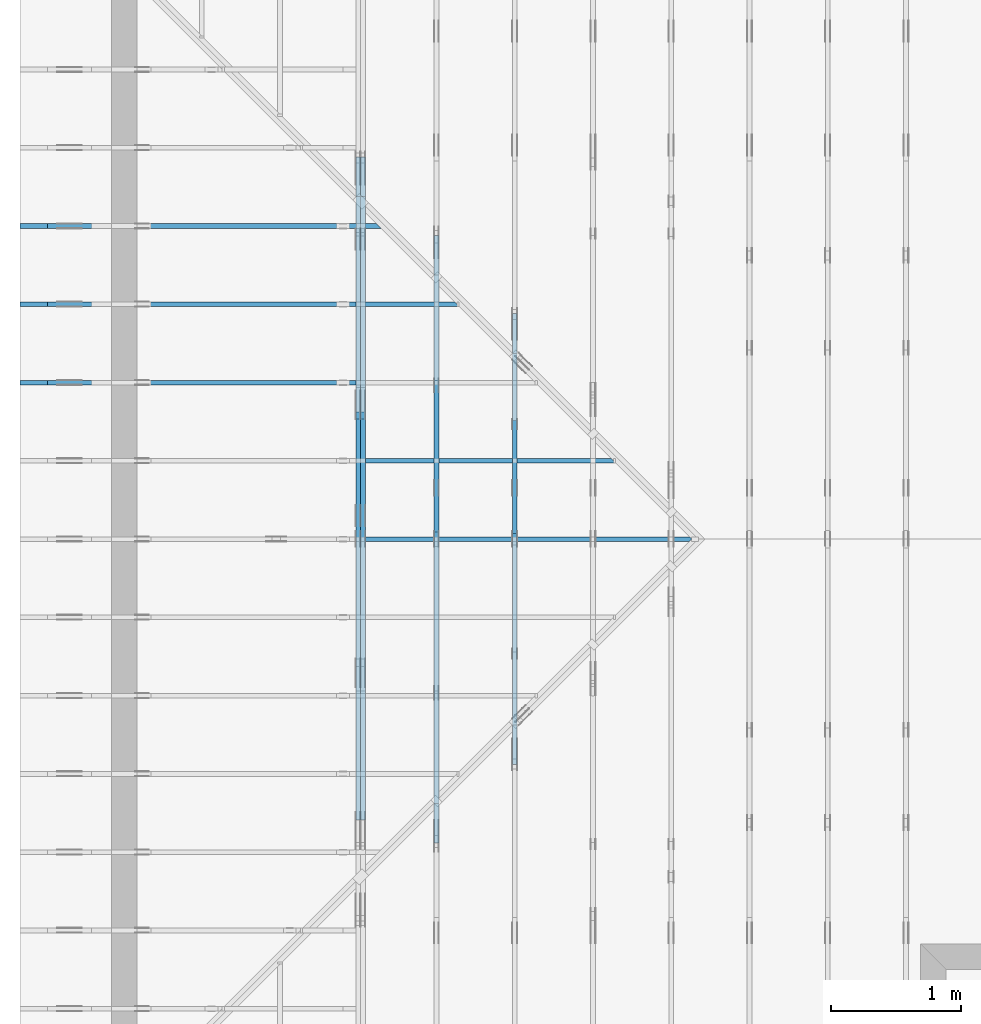
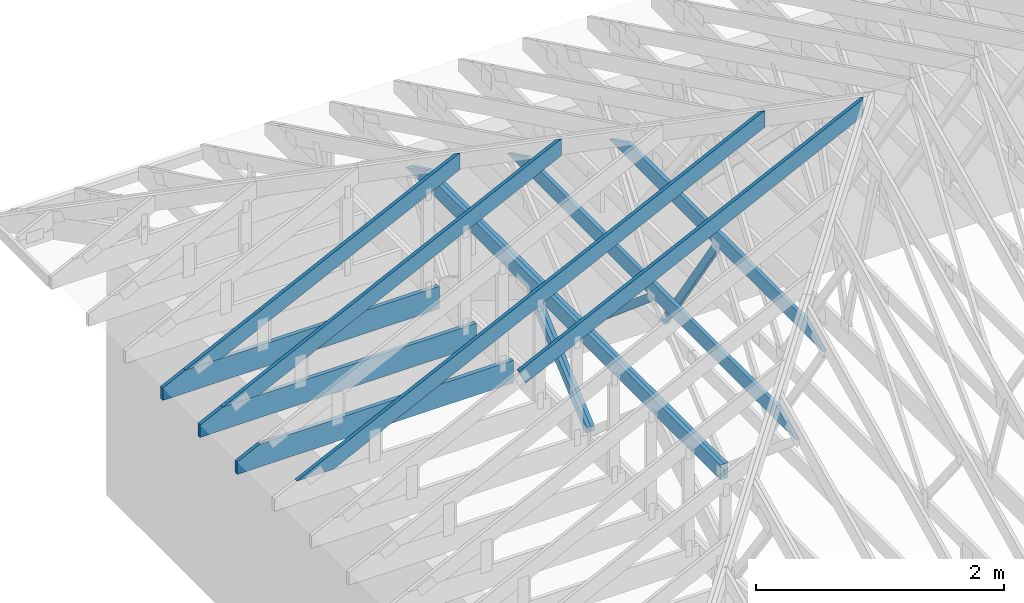
# One storey, part 7 of 159: 15 members, 8 elements without a shape of their own.
"""IFC2X3 building model written with IfcOpenShell, lengths in millimetres."""

from ifc_helpers import new_model, si_unit, frame, origin, origin_with_axes, origin_2d, place, context, project, spatial, faceted_brep, element, aggregate, save


model = new_model("IFC2X3")

# Units and contexts
model_context = context("Model", 3, precision=1e-05, world=origin())
plan_context = context("Plan", 2, precision=1e-05, world=origin_2d())
ifc_project = project(units=[si_unit("LENGTHUNIT", "METRE", prefix="MILLI"), si_unit("AREAUNIT", "SQUARE_METRE"), si_unit("VOLUMEUNIT", "CUBIC_METRE"), si_unit("SOLIDANGLEUNIT", "STERADIAN"), si_unit("PLANEANGLEUNIT", "RADIAN"), si_unit("MASSUNIT", "GRAM"), si_unit("TIMEUNIT", "SECOND"), si_unit("THERMODYNAMICTEMPERATUREUNIT", "DEGREE_CELSIUS"), si_unit("LUMINOUSINTENSITYUNIT", "LUMEN")], contexts=[model_context, plan_context])

# Site, building, storey
site_placement = place(None, origin_with_axes())
site = spatial("IfcSite", under=ifc_project, at=site_placement, CompositionType="ELEMENT")
building_placement = place(site_placement, origin_with_axes())
building = spatial("IfcBuilding", under=site, at=building_placement, Name="Plan 1", CompositionType="ELEMENT")
storey_placement = place(building_placement, origin_with_axes())
storey = spatial("IfcBuildingStorey", under=building, at=storey_placement, Name="Etasje 1", CompositionType="ELEMENT", Elevation=0.0)

# Assembly, member
assembly_1_placement = place(storey_placement, frame((-700.000000000007, 4482.000534935255, 1.1021457184401395e-15), z_axis=(0.0, -1.0, 6.123031769111886e-17), x_axis=(1.0, 0.0, 0.0)))
assembly_1 = element("IfcElementAssembly", 1, at=assembly_1_placement, inside=storey, Name="S1 (23)", AssemblyPlace="FACTORY", PredefinedType="TRUSS")
member_1_placement = place(assembly_1_placement, frame((1996.283952199432, 928.9876521486785, -36.000004249148034), z_axis=(0.0, 0.0, 1.0), x_axis=(0.8987940462991673, 0.43837114678907735, 0.0)))
member_1 = element("IfcMember", 2, at=member_1_placement, Name="S1-O29", context=model_context, shape_type="Brep", body=[
    faceted_brep([(3580.0000763961416, 148.000000161535, 18.000004249150606), (3507.8156524450424, 5.344837177290174e-06, 18.000001218995067), (3487.788816001169, 5.018745241613942e-06, 6.821210263296962e-13), (3559.9732414248656, 148.00000032212813, 4.140368901062175e-06), (3507.81565284729, 1.6058622144292368e-07, 18.000004249148027), (3487.788818359375, 1.6058622622381771e-07, 36.00000424914803), (4.049084132590763e-31, 1.6058686689906988e-07, 36.00000424914803), (1.8367099231598242e-38, 1.6058686469477845e-07, 4.249148027213323e-06), (3487.788818359375, 1.6058622401952628e-07, 4.249148027213323e-06), (3580.0000787542895, 147.9999953034071, 17.999999999927468), (3559.9732423104315, 147.99999497730846, 36.00000121893754), (3487.788818359381, 1.6058686469477834e-07, 36.00000424914788), (3507.8156533306415, 2.2737367544323206e-13, 18.000004140350484), (7.639614159415942e-05, 148.00000016153444, 4.249150464374907e-06), (7.639614159415942e-05, 148.00000016153444, 36.000004249150464), (3559.9732419082256, 148.00000016153422, 36.000004249150464), (3580.0000763961416, 148.00000016153422, 18.000004249150464), (3559.9732419082256, 148.00000016153422, 4.249150464374907e-06), (7.639614204890677e-05, 5.371931592890178e-07, 4.175160519537258e-06), (7.639614205111106e-05, 5.371931592890178e-07, 36.00000424914803), (7.639614206923523e-05, 148.00000331244257, 36.00000485022119), (7.639614206703094e-05, 148.00000331244257, 2.296806940194074e-06), (3559.9732437133853, 148.0000001605872, 36.00000424914803), (5.9117155615240335e-12, 148.0000001605872, 36.00000424914803), (5.9117155615240335e-12, 1.6152262105606496e-07, 36.00000424914803), (3487.7888183593814, 1.6152262105606496e-07, 36.00000424914803), (9.693633455754025e-05, 148.0000001615225, 4.249148027213335e-06), (3559.9732414675846, 148.0000001615225, 4.249148463169908e-06), (3487.7888161135816, 1.6153398973983712e-07, 4.249148454330158e-06), (9.69363350122876e-05, 1.6153398973983712e-07, 4.249148027213335e-06)], [[[0, 1, 2, 3]], [[4, 5, 6, 7, 8]], [[9, 10, 11, 12]], [[13, 14, 15, 16, 17]], [[18, 19, 20, 21]], [[22, 23, 24, 25]], [[26, 27, 28, 29]]]),
])
aggregate(assembly_1, [member_1])

assembly_2_placement = place(storey_placement, frame((-700.000000000007, 5081.993668449246, 1.1021457184401395e-15), z_axis=(0.0, -1.0, 6.123031769111886e-17), x_axis=(1.0, 0.0, 0.0)))
assembly_2 = element("IfcElementAssembly", 3, at=assembly_2_placement, inside=storey, Name="S2 (15)", AssemblyPlace="FACTORY", PredefinedType="TRUSS")
member_2_placement = place(assembly_2_placement, frame((276.06008258286255, 89.9784114862661, -36.000000217582134), z_axis=(0.0, 0.0, 1.0), x_axis=(0.8987940462991673, 0.43837114678907735, 0.0)))
member_2 = element("IfcMember", 4, at=member_2_placement, Name="S2-O8", context=model_context, shape_type="Brep", body=[
    faceted_brep([(4846.397802857349, 147.99999481741372, 36.00000324779239), (4774.21337890625, 7.155449566198513e-10, 36.0000002175816), (4734.159708963717, 3.219075779270497e-07, -4.547473508864641e-13), (4806.3441329148145, 147.99999513860587, 3.0302103368740063e-06), (0.0003410761450481914, 147.99999999999386, 2.175821265382183e-07), (0.0003410761450481914, 147.9999999999941, 36.00000021758213), (4846.397802013646, 147.99999999999378, 36.00000021758213), (4806.3441330378155, 147.99999999999358, 2.175821265382183e-07), (0.0003821565404109606, 148.00000000071233, 2.175821265382651e-07), (4806.344132156541, 148.00000000071233, 2.1758271512617458e-07), (4734.159706802537, 0.0, 2.17582706286424e-07), (303.44520637529064, 0.0, 2.1758216369831107e-07), (303.445127460673, 1.3804992704535834e-09, 2.175821265382183e-07), (303.445127460673, 1.3804992704535834e-09, 36.00000021758213), (0.0001557475417470755, 148.00000154232075, 36.00000021758213), (0.0001557475417470755, 148.00000154232075, 2.175821265382183e-07), (4774.213378024973, 7.207033695502529e-10, 36.00000021758213), (303.44535358039394, 7.21524609189633e-10, 36.00000021758213), (303.44535358039394, 7.215224048981962e-10, 2.175821265382183e-07), (4734.159709049144, 7.207085227554443e-10, 2.175821265382183e-07), (4846.397804260253, 148.00000000071532, 36.00000021758213), (0.0, 148.00000000071532, 36.00000021758213), (303.44531249999994, 1.3808119092573179e-09, 36.00000021758213), (4774.21337890625, 1.3808119092573179e-09, 36.00000021758213)], [[[0, 1, 2, 3]], [[4, 5, 6, 7]], [[8, 9, 10, 11]], [[12, 13, 14, 15]], [[16, 17, 18, 19]], [[20, 21, 22, 23]]]),
])
aggregate(assembly_2, [member_2])

assembly_3_placement = place(storey_placement, frame((-700.000000000007, 5681.993668449246, 1.1021457184401395e-15), z_axis=(0.0, -1.0, 6.123031769111886e-17), x_axis=(1.0, 0.0, 0.0)))
assembly_3 = element("IfcElementAssembly", 5, at=assembly_3_placement, inside=storey, Name="S3 (13)", AssemblyPlace="FACTORY", PredefinedType="TRUSS")
member_3_placement = place(assembly_3_placement, frame((2575.022261404757, 223.00000000093104, -36.0), z_axis=(0.0, 0.0, 1.0), x_axis=(-1.0, 1.2246063538223773e-16, 0.0)))
member_3 = element("IfcMember", 6, at=member_3_placement, Name="S3-U11", context=model_context, shape_type="Brep", body=[
    faceted_brep([(2575.022261404768, 223.00000000093135, 36.0), (4.460788204596611e-05, 223.00000000093135, 36.0), (4.460788204596611e-05, 9.310383575211745e-10, 36.0), (2363.8409717319055, 9.310383575211745e-10, 36.0), (2575.022261404761, 103.00000000093135, 36.0), (4.460788204596611e-05, 223.00000000093135, 5.462709578404924e-21), (2575.022261404768, 223.00000000093135, 3.1533886225503453e-13), (2575.022261404761, 103.00000000093135, 3.1533886225503367e-13), (2363.8409717319055, 9.310383575211745e-10, 2.894774673408554e-13), (4.460788204596611e-05, 9.310383575211745e-10, 5.462709578404924e-21), (1.1401554882727804e-25, 9.310383575211745e-10, -6.981208276421509e-42), (2.2042914369942947e-15, 9.310383575211745e-10, 36.0), (2.9513013127233304e-14, 223.00000000093104, 36.0), (2.730872169035303e-14, 223.00000000093104, -1.6721217048386645e-30), (2363.8409657211496, 5.20089044280899e-13, -3.184521740898993e-29), (2363.8409657211496, 5.222933357177793e-13, 36.0), (8.67712118026388e-28, 9.310405618126114e-10, 36.0), (0.0, 9.310383575211745e-10, 0.0), (2575.022261404761, 103.00000000064097, -3.7865323450608567e-29), (2575.022261404761, 103.00000000064097, 36.0), (2363.8409657211496, 5.684341886080801e-13, 36.0), (2363.8409657211496, 5.684341886080801e-13, -2.524354896707238e-29), (2575.022261404755, 223.00000000093135, -7.825500179792437e-28), (2575.022261404755, 223.00000000093135, 36.0), (2575.022261404755, 103.00000000064031, 36.0), (2575.022261404755, 103.00000000064031, -3.534096855390133e-28), (0.0, 223.00000000093104, 0.0), (0.0, 223.00000000093104, 36.0), (2575.022261404768, 223.00000000093144, 36.0), (2575.022261404768, 223.00000000093146, 6.310887241768095e-30)], [[[0, 1, 2, 3, 4]], [[5, 6, 7, 8, 9]], [[10, 11, 12, 13]], [[14, 15, 16, 17]], [[18, 19, 20, 21]], [[22, 23, 24, 25]], [[26, 27, 28, 29]]]),
])
aggregate(assembly_3, [member_3])

# Assembly, members
assembly_4_placement = place(storey_placement, frame((-700.000000000007, 6281.993668449246, 1.1021457184401395e-15), z_axis=(0.0, -1.0, 6.123031769111886e-17), x_axis=(1.0, 0.0, 0.0)))
assembly_4 = element("IfcElementAssembly", 7, at=assembly_4_placement, inside=storey, Name="S4 (11)", AssemblyPlace="FACTORY", PredefinedType="TRUSS")
member_4_placement = place(assembly_4_placement, frame((276.06015701956005, 89.9784477906785, -36.000000217603755), z_axis=(0.0, 0.0, 1.0), x_axis=(0.898794046299167, 0.4383711467890774, 0.0)))
member_4 = element("IfcMember", 8, at=member_4_placement, Name="S4-O30", context=model_context, shape_type="Brep", body=[
    faceted_brep([(3511.275391469473, 147.9999948191005, 36.00000324784082), (3439.090967518422, 2.3792381398379803e-09, 36.00000021760275), (3399.0372975759083, 3.235552412661491e-07, -6.821210263296962e-13), (3471.2217215269584, 147.99999514027718, 3.0302364848466823e-06), (0.0, 147.99999999998397, 2.1760374835366747e-07), (0.0, 147.99999999998397, 36.00000021760375), (3511.2753906250005, 147.99999999998374, 36.00000021760375), (3471.2217216491704, 147.99999999998377, 2.1760374835366747e-07), (4.108040155870185e-05, 148.00000000142342, 2.176037483536725e-07), (3471.2217207679014, 148.00000000142342, 2.1760417344168495e-07), (3399.037295413898, 2.2737367544323206e-13, 2.1760416460193436e-07), (303.4451094397764, 2.2737367544323206e-13, 2.176037855137484e-07), (303.4450446442796, 1.274585770261183e-09, 2.1760374835366747e-07), (303.4450446442796, 1.274585770261183e-09, 36.00000021760375), (7.293114835249526e-05, 148.00000154221485, 36.00000021760375), (7.293114835249526e-05, 148.00000154221485, 2.1760374835366747e-07), (3439.090966637138, 2.3646451967991434e-09, 36.00000021760375), (303.445012505058, 2.3652211865929584e-09, 36.00000021760375), (303.445012505058, 2.3652189823015215e-09, 2.1760374835366747e-07), (3399.037297661308, 2.3646503500043346e-09, 2.1760374835366747e-07), (3511.275392872425, 148.00000000237947, 36.00000021760375), (0.0001472059211096166, 148.00000000237947, 36.00000021760375), (303.44497142467117, 1.274514715987607e-09, 36.00000021760375), (3439.090967518421, 1.274514715987607e-09, 36.00000021760375)], [[[0, 1, 2, 3]], [[4, 5, 6, 7]], [[8, 9, 10, 11]], [[12, 13, 14, 15]], [[16, 17, 18, 19]], [[20, 21, 22, 23]]]),
])
member_5_placement = place(assembly_4_placement, frame((2575.022261404757, 223.00000000093104, -36.0), z_axis=(0.0, 0.0, 1.0), x_axis=(-1.0, 1.2246063538223773e-16, 0.0)))
member_5 = element("IfcMember", 9, at=member_5_placement, Name="S4-U11", context=model_context, shape_type="Brep", body=[
    faceted_brep([(2575.022261404768, 223.00000000093135, 36.0), (4.460788204596611e-05, 223.00000000093135, 36.0), (4.460788204596611e-05, 9.310383575211745e-10, 36.0), (2363.8409717319055, 9.310383575211745e-10, 36.0), (2575.022261404761, 103.00000000093135, 36.0), (4.460788204596611e-05, 223.00000000093135, 5.462709578404924e-21), (2575.022261404768, 223.00000000093135, 3.1533886225503453e-13), (2575.022261404761, 103.00000000093135, 3.1533886225503367e-13), (2363.8409717319055, 9.310383575211745e-10, 2.894774673408554e-13), (4.460788204596611e-05, 9.310383575211745e-10, 5.462709578404924e-21), (1.1401554882727804e-25, 9.310383575211745e-10, -6.981208276421509e-42), (2.2042914369942947e-15, 9.310383575211745e-10, 36.0), (2.9513013127233304e-14, 223.00000000093104, 36.0), (2.730872169035303e-14, 223.00000000093104, -1.6721217048386645e-30), (2363.8409657211496, 5.20089044280899e-13, -3.184521740898993e-29), (2363.8409657211496, 5.222933357177793e-13, 36.0), (8.67712118026388e-28, 9.310405618126114e-10, 36.0), (0.0, 9.310383575211745e-10, 0.0), (2575.022261404761, 103.00000000064097, -3.7865323450608567e-29), (2575.022261404761, 103.00000000064097, 36.0), (2363.8409657211496, 5.684341886080801e-13, 36.0), (2363.8409657211496, 5.684341886080801e-13, -2.524354896707238e-29), (2575.022261404755, 223.00000000093135, -7.825500179792437e-28), (2575.022261404755, 223.00000000093135, 36.0), (2575.022261404755, 103.00000000064031, 36.0), (2575.022261404755, 103.00000000064031, -3.534096855390133e-28), (0.0, 223.00000000093104, 0.0), (0.0, 223.00000000093104, 36.0), (2575.022261404768, 223.00000000093144, 36.0), (2575.022261404768, 223.00000000093146, 6.310887241768095e-30)], [[[0, 1, 2, 3, 4]], [[5, 6, 7, 8, 9]], [[10, 11, 12, 13]], [[14, 15, 16, 17]], [[18, 19, 20, 21]], [[22, 23, 24, 25]], [[26, 27, 28, 29]]]),
])
aggregate(assembly_4, [member_4, member_5])

assembly_5_placement = place(storey_placement, frame((-700.000000000007, 6881.993668449246, 1.1021457184401395e-15), z_axis=(0.0, -1.0, 6.123031769111886e-17), x_axis=(1.0, 0.0, 0.0)))
assembly_5 = element("IfcElementAssembly", 10, at=assembly_5_placement, inside=storey, Name="S5 (9)", AssemblyPlace="FACTORY", PredefinedType="TRUSS")
member_6_placement = place(assembly_5_placement, frame((276.06017326637647, 89.97845571530922, -36.000000217573344), z_axis=(0.0, 0.0, 1.0), x_axis=(0.898794046299167, 0.4383711467890774, 0.0)))
member_6 = element("IfcMember", 11, at=member_6_placement, Name="S5-O40", context=model_context, shape_type="Brep", body=[
    faceted_brep([(2843.714209107352, 147.99999481740474, 36.000003247754194), (2771.52978515625, 7.07927938492503e-10, 36.00000021757319), (2731.476115213709, 3.2189734611165477e-07, 0.0), (2803.66053916481, 147.99999513859427, 3.030180323548848e-06), (9.6935520673469e-05, 147.9999999999867, 2.175733442300043e-07), (9.6935520673469e-05, 147.9999999999867, 36.00000021757335), (2843.714208263646, 147.99999999998653, 36.00000021757335), (2803.6605392878155, 147.99999999998653, 2.175733442300043e-07), (0.00013801592302797872, 148.00000000094744, 2.175733442300212e-07), (2803.6605384065483, 148.00000000094744, 2.1757368756805522e-07), (2731.476113052544, 5.684341886080802e-14, 2.1757367872830464e-07), (303.44496223467297, 5.684341886080802e-14, 2.1757338139006719e-07), (303.4450265678085, 7.994174211489735e-10, 2.175733442300043e-07), (303.4450265678085, 7.994174211489735e-10, 36.000000217573344), (5.485467718813197e-05, 148.0000015417397, 36.000000217573344), (5.485467718813197e-05, 148.0000015417397, 2.175733442300043e-07), (2771.529784274977, 7.086920218428738e-10, 36.000000217573344), (303.4451094397713, 7.0914538666906e-10, 36.000000217573344), (303.4451094397713, 7.093749969451649e-10, 2.175733442300043e-07), (2731.476115299147, 7.089289896156069e-10, 2.175733442300043e-07), (2843.714210510254, 148.0000000007081, 36.000000217573344), (0.0, 148.0000000007081, 36.000000217573344), (303.445068359375, 7.996163731149863e-10, 36.000000217573344), (2771.52978515625, 7.996163731149863e-10, 36.000000217573344)], [[[0, 1, 2, 3]], [[4, 5, 6, 7]], [[8, 9, 10, 11]], [[12, 13, 14, 15]], [[16, 17, 18, 19]], [[20, 21, 22, 23]]]),
])
member_7_placement = place(assembly_5_placement, frame((2575.0222614047557, 223.00000000093104, -36.0), z_axis=(0.0, 0.0, 1.0), x_axis=(-1.0, 1.2246063538223773e-16, 0.0)))
member_7 = element("IfcMember", 12, at=member_7_placement, Name="S5-U11", context=model_context, shape_type="Brep", body=[
    faceted_brep([(2575.0222614047666, 223.00000000093135, 36.0), (4.4607880681724055e-05, 223.00000000093135, 36.0), (4.4607880681724055e-05, 9.310383575211745e-10, 36.0), (2363.840971731904, 9.310383575211745e-10, 36.0), (2575.02226140476, 103.00000000093135, 36.0), (4.4607880681724055e-05, 223.00000000093135, 5.4627094113389755e-21), (2575.0222614047666, 223.00000000093135, 3.153388622550344e-13), (2575.02226140476, 103.00000000093135, 3.153388622550335e-13), (2363.840971731904, 9.310383575211745e-10, 2.894774673408552e-13), (4.4607880681724055e-05, 9.310383575211745e-10, 5.4627094113389755e-21), (1.1401554882727804e-25, 9.310383575211745e-10, -6.981208276421509e-42), (2.2042914369942947e-15, 9.310383575211745e-10, 36.0), (2.9513013127233304e-14, 223.00000000093104, 36.0), (2.730872169035303e-14, 223.00000000093104, -1.6721217048386645e-30), (2363.840965721148, 5.20089044281416e-13, -3.184521740902437e-29), (2363.840965721148, 5.222933357182963e-13, 36.0), (8.67712118026388e-28, 9.310405618126114e-10, 36.0), (0.0, 9.310383575211745e-10, 0.0), (2575.022261404759, 103.00000000064074, -5.048709793414476e-29), (2575.022261404759, 103.00000000064074, 36.0), (2363.840965721148, 6.821210263296962e-13, 36.0), (2363.840965721148, 6.821210263296962e-13, -3.7865323450608567e-29), (2575.022261404754, 223.00000000093135, -7.825500179792437e-28), (2575.022261404754, 223.00000000093135, 36.0), (2575.022261404754, 103.00000000064031, 36.0), (2575.022261404754, 103.00000000064031, -3.534096855390133e-28), (0.0, 223.00000000093104, 0.0), (0.0, 223.00000000093104, 36.0), (2575.0222614047666, 223.00000000093144, 36.0), (2575.0222614047666, 223.00000000093146, 6.310887241768095e-30)], [[[0, 1, 2, 3, 4]], [[5, 6, 7, 8, 9]], [[10, 11, 12, 13]], [[14, 15, 16, 17]], [[18, 19, 20, 21]], [[22, 23, 24, 25]], [[26, 27, 28, 29]]]),
])
aggregate(assembly_5, [member_6, member_7])

assembly_6_placement = place(storey_placement, frame((3075.02226140475, 9699.999999999993, 1.1021457184401395e-15), z_axis=(-1.0, 1.836909530733566e-16, 6.123031769111886e-17), x_axis=(-1.836909530733566e-16, -1.0, 0.0)))
assembly_6 = element("IfcElementAssembly", 13, at=assembly_6_placement, inside=storey, Name="V3 (4)", AssemblyPlace="FACTORY", PredefinedType="TRUSS")
member_8_placement = place(assembly_6_placement, frame((3471.577292853879, 1648.5362548828125, -36.0), z_axis=(0.0, 0.0, 1.0), x_axis=(1.0, 0.0, 0.0)))
member_8 = element("IfcMember", 14, at=member_8_placement, Name="V3-O32", context=model_context, shape_type="Brep", body=[
    faceted_brep([(3153.399269646121, 148.0, 36.0), (303.44492394299596, 148.0, 36.0), (9.972424595616758e-05, 0.0, 36.0), (3456.844582146121, 0.0, 36.0), (303.44492394299596, 148.0, 3.7160058189574085e-14), (3153.399269646121, 148.0, 3.8616727817474837e-13), (3456.844582146121, 0.0, 4.2332738394726006e-13), (9.972424595616758e-05, 0.0, 1.2212294522806833e-20), (2.912607492428637e-17, 3.737555380206171e-05, -4.0681508493257726e-33), (9.954246492837812e-16, 3.737555380008051e-05, 36.0), (303.44496855381294, 148.0000373755611, 36.0), (303.44496855381294, 148.0000373755611, 1.385899187981055e-30), (3456.844344425437, 3.7375547026541307e-05, -3.063827246277004e-29), (3456.844344425437, 3.73755470287456e-05, 36.0), (4.320510866616801e-30, 3.737555380432572e-05, 36.0), (0.0, 3.737555380212143e-05, 0.0), (3153.3993758717697, 148.0000373755463, -1.262177448353619e-29), (3153.3993758717697, 148.0000373755463, 36.0), (3456.844344425437, 3.737554629879014e-05, 36.0), (3456.844344425437, 3.737554629879014e-05, -1.262177448353619e-29), (303.44496855381294, 148.00003737556108, -1.5777218104420236e-30), (303.44496855381294, 148.00003737556108, 36.0), (3153.3993758717697, 148.00003737554636, 36.0), (3153.3993758717697, 148.00003737554636, -1.1044052673094165e-29)], [[[0, 1, 2, 3]], [[4, 5, 6, 7]], [[8, 9, 10, 11]], [[12, 13, 14, 15]], [[16, 17, 18, 19]], [[20, 21, 22, 23]]]),
])
member_9_placement = place(assembly_6_placement, frame((5169.766918726358, 1668.9876108366473, -36.0), z_axis=(0.0, 0.0, 1.0), x_axis=(-0.5603073033833335, -0.8282848095765714, 0.0)))
member_9 = element("IfcMember", 15, at=member_9_placement, Name="V3-D27", context=model_context, shape_type="Brep", body=[
    faceted_brep([(1517.6965755224533, 73.00028312683662, 36.0), (53.95681495351528, 73.00028312683662, 36.0), (4.817951776203699e-06, 36.500241634735175, 36.0), (24.691007661233925, 0.0003022892879016581, 36.0), (1567.0788547965685, 0.0003022892879016581, 36.0), (53.95681495351528, 73.00028312683662, 6.607585842409306e-15), (1517.6965755224533, 73.00028312683662, 1.8585808695592598e-13), (1567.0788547965685, 0.0003022892879016581, 1.9190547225245724e-13), (24.691007661233925, 0.0003022892879016581, 3.023676486422406e-15), (4.817951776203699e-06, 36.500241634735175, 5.9000943575488585e-22), (3.552713678800501e-15, 36.500182051514, 0.0), (3.552713678800501e-15, 36.500182051513995, 36.0), (53.9568114980293, 73.000182051514, 36.0), (53.9568114980293, 73.000182051514, 0.0), (24.69104387408242, 0.00018205151399719455, 1.972152263052529e-31), (24.691043874082425, 0.0001820515139989709, 36.0), (1.4210854715202004e-14, 36.50018205151402, 36.0), (1.0658141036401503e-14, 36.50018205151402, -9.860761315262648e-31), (1567.0787316447354, 0.00018205151371466542, 1.7625647424139114e-29), (1567.0787316447354, 0.0001820515137168697, 36.0), (24.691043874082425, 0.0001820515140001924, 36.0), (24.691043874082425, 0.0001820515139979881, 2.7771157481679415e-31), (1517.696643896569, 73.000182051514, -1.262177448353619e-29), (1517.696643896569, 73.000182051514, 36.0), (1567.0787316447352, 0.00018205151400252362, 36.0), (1567.0787316447352, 0.00018205151400252362, -1.262177448353619e-29), (53.95681149802931, 73.000182051514, 0.0), (53.95681149802931, 73.000182051514, 36.0), (1517.6966438965692, 73.0001820515139, 36.0), (1517.6966438965692, 73.0001820515139, -5.5220263365470826e-30)], [[[0, 1, 2, 3, 4]], [[5, 6, 7, 8, 9]], [[10, 11, 12, 13]], [[14, 15, 16, 17]], [[18, 19, 20, 21]], [[22, 23, 24, 25]], [[26, 27, 28, 29]]]),
])
aggregate(assembly_6, [member_8, member_9])

assembly_7_placement = place(storey_placement, frame((2475.02226140475, 9699.999999999993, 1.1021457184401395e-15), z_axis=(-1.0, 1.836909530733566e-16, 6.123031769111886e-17), x_axis=(-1.836909530733566e-16, -1.0, 0.0)))
assembly_7 = element("IfcElementAssembly", 16, at=assembly_7_placement, inside=storey, Name="V2 (3)", AssemblyPlace="FACTORY", PredefinedType="TRUSS")
member_10_placement = place(assembly_7_placement, frame((2871.5772928528604, 1355.896728515625, -36.0), z_axis=(0.0, 0.0, 1.0), x_axis=(1.0, 0.0, 0.0)))
member_10 = element("IfcMember", 17, at=member_10_placement, Name="V2-O14", context=model_context, shape_type="Brep", body=[
    faceted_brep([(4353.39926964714, 148.0, 36.0), (303.4449239440146, 148.0, 36.0), (9.972526459023356e-05, 0.0, 36.0), (4656.84458214714, 0.0, 36.0), (303.4449239440146, 148.0, 3.7160058189698826e-14), (4353.39926964714, 148.0, 5.331200406335583e-13), (4656.84458214714, 0.0, 5.7028014640607e-13), (9.972526459023356e-05, 0.0, 1.2212419265381775e-20), (-1.4408049914553436e-14, 1.0603216680902314e-05, 2.0124714371670898e-30), (-1.3441752187226888e-14, 1.060321667892111e-05, 36.0), (303.4449685537111, 148.00001060322398, 36.0), (303.4449685537111, 148.00001060322398, 4.666143257340491e-30), (4656.844344427416, 1.0603228204267212e-05, 1.836303014975739e-28), (4656.844344427416, 1.0603228206471503e-05, 36.0), (-5.468503539686346e-30, 1.0603216653565727e-05, 36.0), (0.0, 1.0603216651361436e-05, 0.0), (4353.399375873865, 148.0000106032312, -2.524354896707238e-29), (4353.399375873865, 148.0000106032312, 36.0), (4656.844344427416, 1.060323143065034e-05, 36.0), (4656.844344427416, 1.060323143065034e-05, -2.524354896707238e-29), (303.444968553711, 148.0000106032239, -1.5777218104420236e-30), (303.444968553711, 148.0000106032239, 36.0), (4353.399375873865, 148.00001060323086, 36.0), (4353.399375873865, 148.00001060323086, -2.0510383535746307e-29)], [[[0, 1, 2, 3]], [[4, 5, 6, 7]], [[8, 9, 10, 11]], [[12, 13, 14, 15]], [[16, 17, 18, 19]], [[20, 21, 22, 23]]]),
])
member_11_placement = place(assembly_7_placement, frame((5176.425387456267, 1383.7628547007882, -36.0), z_axis=(0.0, 0.0, 1.0), x_axis=(-0.7634525540155754, -0.6458639158267745, 0.0)))
member_11 = element("IfcMember", 18, at=member_11_placement, Name="V2-D26", context=model_context, shape_type="Brep", body=[
    faceted_brep([(1481.783937061124, 73.00005535136233, 36.0), (30.87816093278707, 73.00005535136233, 36.0), (0.0, 36.500141414936934, 36.0), (43.145507129766884, 0.0, 36.0), (1568.0745785410904, 0.0, 36.0), (30.87816093278707, 73.00005535136233, 3.7813592072640944e-15), (1481.783937061124, 73.00005535136233, 1.81460202431699e-13), (1568.0745785410904, 0.0, 1.9202740921487657e-13), (43.145507129766884, 0.0, 5.283626217000121e-15), (0.0, 36.500141414936934, 0.0), (2.876841426768806e-05, 36.50010318898013, 1.9721522630525295e-31), (2.876841426768806e-05, 36.50010318898013, 36.0), (30.878218648924292, 73.00010318897921, 36.0), (30.878218648924292, 73.00010318897921, 1.9721522630525295e-31), (43.14536873666022, 0.00010318897967565022, -7.888609052210118e-31), (43.14536873666022, 0.00010318897967565022, 36.0), (2.8768414264135345e-05, 36.50010318898012, 36.0), (2.8768414264135345e-05, 36.50010318898012, 1.9721522630525295e-31), (1568.074560450486, 0.00010318897800995364, 4.5649879623674857e-29), (1568.074560450486, 0.00010318897801215793, 36.0), (43.1453687366602, 0.00010318897964668283, 36.0), (43.1453687366602, 0.00010318897964447854, 1.2560501323282063e-30), (1481.7838805139945, 73.00010318897876, 0.0), (1481.7838805139945, 73.00010318897876, 36.0), (1568.074560450486, 0.00010318897875549737, 36.0), (1568.074560450486, 0.00010318897875549737, 1.262177448353619e-29), (30.8782186489243, 73.00010318897921, 0.0), (30.8782186489243, 73.00010318897921, 36.0), (1481.7838805139945, 73.0001031889788, 36.0), (1481.7838805139945, 73.0001031889788, 2.3665827156630354e-30)], [[[0, 1, 2, 3, 4]], [[5, 6, 7, 8, 9]], [[10, 11, 12, 13]], [[14, 15, 16, 17]], [[18, 19, 20, 21]], [[22, 23, 24, 25]], [[26, 27, 28, 29]]]),
])
aggregate(assembly_7, [member_10, member_11])

assembly_8_placement = place(storey_placement, frame((1875.0222614047502, 9699.999999999993, 0.0), z_axis=(-1.0, 1.836909530733566e-16, 6.123031769111886e-17), x_axis=(-1.836909530733566e-16, -1.0, 0.0)))
assembly_8 = element("IfcElementAssembly", 19, at=assembly_8_placement, inside=storey, Name="V1 (2)", AssemblyPlace="FACTORY", PredefinedType="TRUSS")
member_12_placement = place(assembly_8_placement, frame((2271.5772928515216, 1063.2571859793316, -36.0), z_axis=(0.0, 0.0, 1.0), x_axis=(1.0, 0.0, 0.0)))
member_12 = element("IfcMember", 20, at=member_12_placement, Name="V1-O5", context=model_context, shape_type="Brep", body=[
    faceted_brep([(5079.999855585978, 148.00001616910595, 36.0), (303.44492394535337, 148.00001616910595, 36.0), (9.972660336643457e-05, 1.616910594748333e-05, 36.0), (5079.999855585978, 1.616910594748333e-05, 36.0), (303.44492394535337, 148.00001616910595, 3.7160058189862776e-14), (5079.999855585978, 148.00001616910595, 6.221000100567348e-13), (5079.999855585978, 1.616910594748333e-05, 6.221000100567348e-13), (9.972660336643457e-05, 1.616910594748333e-05, 1.2212583212765986e-20), (0.0, 0.0, 0.0), (9.662977650431006e-16, -1.981204019775963e-15, 36.0), (303.44496855350735, 147.9999999999927, 36.0), (303.44496855350735, 147.9999999999927, -1.5777218104420236e-30), (5080.000000000001, -9.331500416126517e-13, 1.267478854113557e-28), (5080.000000000001, -9.309457501757714e-13, 36.0), (4.049083948919771e-31, 2.204291436880279e-15, 36.0), (0.0, 0.0, 0.0), (5080.000000000001, 148.00000000000114, 0.0), (5080.000000000001, 148.00000000000114, 36.0), (5080.000000000001, 1.1368683772161603e-12, 36.0), (5080.000000000001, 1.1368683772161603e-12, 0.0), (303.4449685535073, 147.9999999999927, -1.5777218104420236e-30), (303.4449685535073, 147.9999999999927, 36.0), (5080.000000000001, 148.00000000000088, 36.0), (5080.000000000001, 148.0000000000009, -1.4199496293978212e-29)], [[[0, 1, 2, 3]], [[4, 5, 6, 7]], [[8, 9, 10, 11]], [[12, 13, 14, 15]], [[16, 17, 18, 19]], [[20, 21, 22, 23]]]),
])
member_13_placement = place(assembly_8_placement, frame((2271.5772928515216, 1063.2571859793316, -72.0), z_axis=(0.0, 0.0, 1.0), x_axis=(1.0, 0.0, 0.0)))
member_13 = element("IfcMember", 21, at=member_13_placement, Name="V1-O5", context=model_context, shape_type="Brep", body=[
    faceted_brep([(5079.999855585978, 148.00001616910595, 36.0), (303.44492394535337, 148.00001616910595, 36.0), (9.972660336643457e-05, 1.616910594748333e-05, 36.0), (5079.999855585978, 1.616910594748333e-05, 36.0), (303.44492394535337, 148.00001616910595, 3.7160058189862776e-14), (5079.999855585978, 148.00001616910595, 6.221000100567348e-13), (5079.999855585978, 1.616910594748333e-05, 6.221000100567348e-13), (9.972660336643457e-05, 1.616910594748333e-05, 1.2212583212765986e-20), (0.0, 0.0, 0.0), (9.662977650431006e-16, -1.981204019775963e-15, 36.0), (303.44496855350735, 147.9999999999927, 36.0), (303.44496855350735, 147.9999999999927, -1.5777218104420236e-30), (5080.000000000001, -9.331500416126517e-13, 1.267478854113557e-28), (5080.000000000001, -9.309457501757714e-13, 36.0), (4.049083948919771e-31, 2.204291436880279e-15, 36.0), (0.0, 0.0, 0.0), (5080.000000000001, 148.00000000000114, 0.0), (5080.000000000001, 148.00000000000114, 36.0), (5080.000000000001, 1.1368683772161603e-12, 36.0), (5080.000000000001, 1.1368683772161603e-12, 0.0), (303.4449685535073, 147.9999999999927, -1.5777218104420236e-30), (303.4449685535073, 147.9999999999927, 36.0), (5080.000000000001, 148.00000000000088, 36.0), (5080.000000000001, 148.0000000000009, -1.4199496293978212e-29)], [[[0, 1, 2, 3]], [[4, 5, 6, 7]], [[8, 9, 10, 11]], [[12, 13, 14, 15]], [[16, 17, 18, 19]], [[20, 21, 22, 23]]]),
])
member_14_placement = place(assembly_8_placement, frame((4200.046590037857, 1035.5942148503364, -36.0), z_axis=(0.0, 0.0, 1.0), x_axis=(0.7578872008604178, -0.6523856150866301, 0.0)))
member_14 = element("IfcMember", 22, at=member_14_placement, Name="V1-D39", context=model_context, shape_type="Brep", body=[
    faceted_brep([(1256.5572844088492, 73.00013608236668, 36.0), (42.40255655847977, 73.00013608236668, 36.0), (9.989393493015086e-05, 36.500223827584705, 36.0), (92.31325157664696, 0.0002203411463597149, 36.0), (1245.573470749248, 0.0002203411463597149, 36.0), (1287.9762974759028, 36.500223827584705, 36.0), (42.40255655847977, 73.00013608236668, 5.192644017982704e-15), (1256.5572844088492, 73.00013608236668, 1.5387880344288687e-13), (1287.9762974759028, 36.500223827584705, 1.577263957461611e-13), (1245.573470749248, 0.0002203411463597149, 1.52533718643212e-13), (92.31325157664696, 0.0002203411463597149, 1.1304739442276545e-14), (9.989393493015086e-05, 36.500223827584705, 1.2233074742378186e-20), (3.552713678800501e-15, 36.500116504919326, -3.944304526105059e-31), (3.552713678800501e-15, 36.500116504919326, 36.0), (42.40265602381896, 73.0001165049207, 36.0), (42.40265602381896, 73.0001165049207, -1.9721522630525295e-31), (92.31310374423629, 0.00011650491930836893, 1.3131877613890576e-30), (92.31310374423629, 0.00011650491931192164, 36.0), (1.7763568394002505e-15, 36.50011650491935, 36.0), (1.7763568394002505e-15, 36.50011650491934, -7.475045549225287e-31), (1245.5736060942213, 0.0001165049160403653, 6.713362965794724e-30), (1245.5736060942213, 0.00011650491604256959, 36.0), (92.31310374423629, 0.00011650491932731638, 36.0), (92.31310374423629, 0.00011650491932511208, 4.975474501719828e-31), (1287.9762621180507, 36.50011650491933, 0.0), (1287.9762621180507, 36.50011650491933, 36.0), (1245.5736060942213, 0.00011650491615000647, 36.0), (1245.5736060942213, 0.00011650491615000647, 0.0), (1256.5572397046674, 73.00011650491706, -4.711188344320561e-30), (1256.5572397046674, 73.00011650491706, 36.0), (1287.9762621180507, 36.50011650491945, 36.0), (1287.9762621180507, 36.50011650491945, -5.007998499247298e-30), (42.40265602381897, 73.0001165049207, 0.0), (42.40265602381897, 73.0001165049207, 36.0), (1256.5572397046672, 73.00011650491712, 36.0), (1256.5572397046672, 73.00011650491712, 3.1554436208840472e-30)], [[[0, 1, 2, 3, 4, 5]], [[6, 7, 8, 9, 10, 11]], [[12, 13, 14, 15]], [[16, 17, 18, 19]], [[20, 21, 22, 23]], [[24, 25, 26, 27]], [[28, 29, 30, 31]], [[32, 33, 34, 35]]]),
])
member_15_placement = place(assembly_8_placement, frame((4200.046590037857, 1035.5942148503364, -72.0), z_axis=(0.0, 0.0, 1.0), x_axis=(0.7578872008604178, -0.6523856150866301, 0.0)))
member_15 = element("IfcMember", 23, at=member_15_placement, Name="V1-D39", context=model_context, shape_type="Brep", body=[
    faceted_brep([(1256.5572844088492, 73.00013608236668, 36.0), (42.40255655847977, 73.00013608236668, 36.0), (9.989393493015086e-05, 36.500223827584705, 36.0), (92.31325157664696, 0.0002203411463597149, 36.0), (1245.573470749248, 0.0002203411463597149, 36.0), (1287.9762974759028, 36.500223827584705, 36.0), (42.40255655847977, 73.00013608236668, 5.192644017982704e-15), (1256.5572844088492, 73.00013608236668, 1.5387880344288687e-13), (1287.9762974759028, 36.500223827584705, 1.577263957461611e-13), (1245.573470749248, 0.0002203411463597149, 1.52533718643212e-13), (92.31325157664696, 0.0002203411463597149, 1.1304739442276545e-14), (9.989393493015086e-05, 36.500223827584705, 1.2233074742378186e-20), (3.552713678800501e-15, 36.500116504919326, -3.944304526105059e-31), (3.552713678800501e-15, 36.500116504919326, 36.0), (42.40265602381896, 73.0001165049207, 36.0), (42.40265602381896, 73.0001165049207, -1.9721522630525295e-31), (92.31310374423629, 0.00011650491930836893, 1.3131877613890576e-30), (92.31310374423629, 0.00011650491931192164, 36.0), (1.7763568394002505e-15, 36.50011650491935, 36.0), (1.7763568394002505e-15, 36.50011650491934, -7.475045549225287e-31), (1245.5736060942213, 0.0001165049160403653, 6.713362965794724e-30), (1245.5736060942213, 0.00011650491604256959, 36.0), (92.31310374423629, 0.00011650491932731638, 36.0), (92.31310374423629, 0.00011650491932511208, 4.975474501719828e-31), (1287.9762621180507, 36.50011650491933, 0.0), (1287.9762621180507, 36.50011650491933, 36.0), (1245.5736060942213, 0.00011650491615000647, 36.0), (1245.5736060942213, 0.00011650491615000647, 0.0), (1256.5572397046674, 73.00011650491706, -4.711188344320561e-30), (1256.5572397046674, 73.00011650491706, 36.0), (1287.9762621180507, 36.50011650491945, 36.0), (1287.9762621180507, 36.50011650491945, -5.007998499247298e-30), (42.40265602381897, 73.0001165049207, 0.0), (42.40265602381897, 73.0001165049207, 36.0), (1256.5572397046672, 73.00011650491712, 36.0), (1256.5572397046672, 73.00011650491712, 3.1554436208840472e-30)], [[[0, 1, 2, 3, 4, 5]], [[6, 7, 8, 9, 10, 11]], [[12, 13, 14, 15]], [[16, 17, 18, 19]], [[20, 21, 22, 23]], [[24, 25, 26, 27]], [[28, 29, 30, 31]], [[32, 33, 34, 35]]]),
])
aggregate(assembly_8, [member_12, member_13, member_14, member_15])

save(model, "model.ifc")
